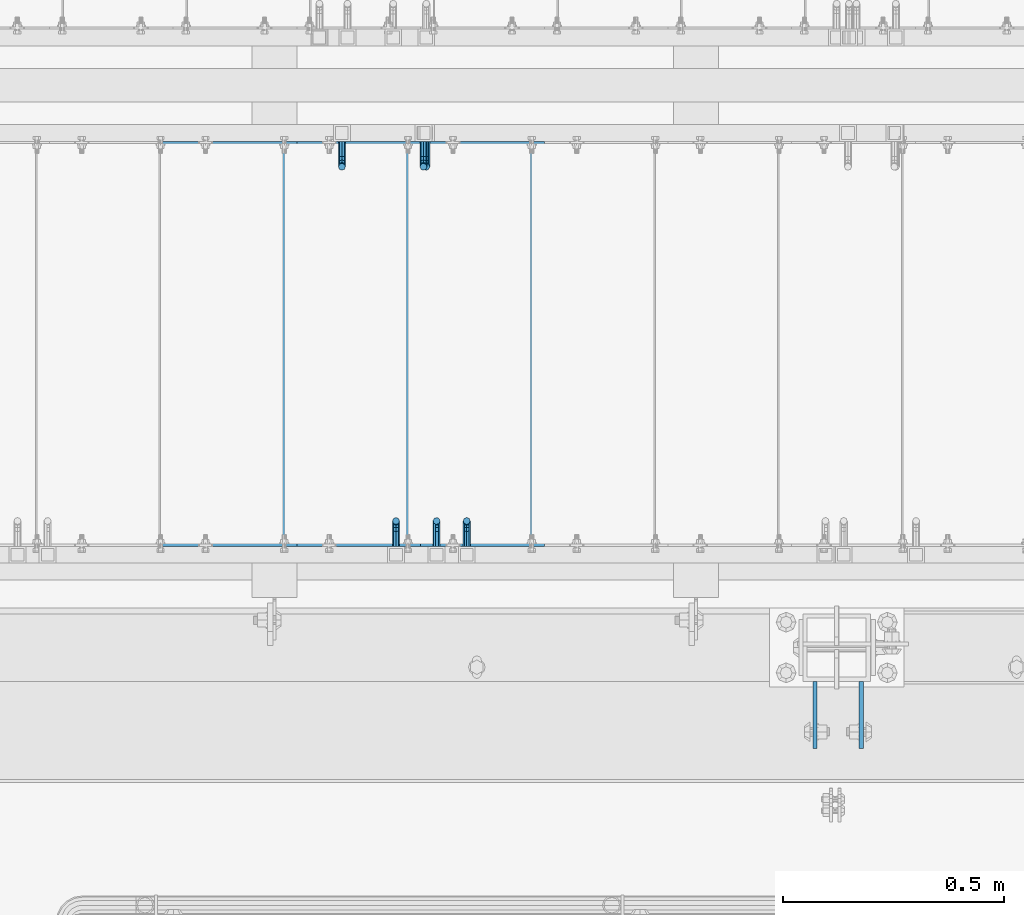
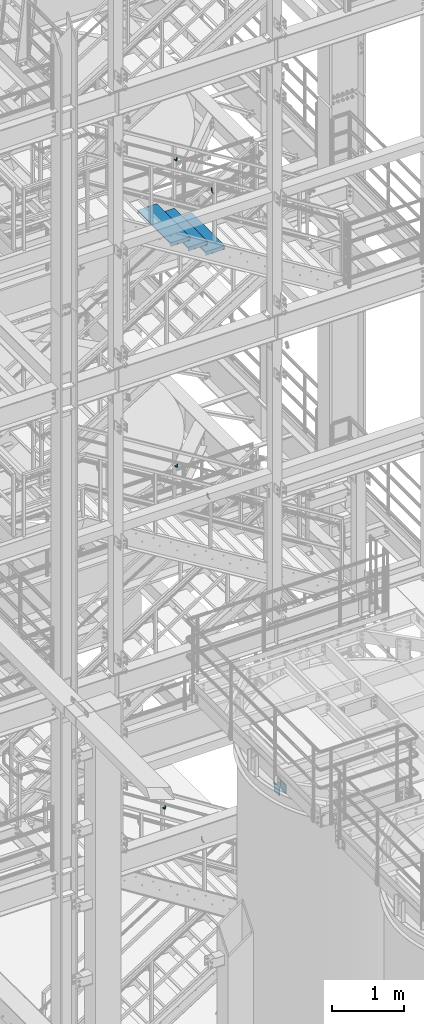
# One storey, part 1147 of 1876: 11 beams, 8 elements without a shape of their own.
"""IFC2X3 building model written with IfcOpenShell, lengths in millimetres."""

from ifc_helpers import new_model, si_unit, frame, origin_with_axes, place, context, subcontext, project, spatial, faceted_brep, material, type_object, element, aggregate, save


model = new_model("IFC2X3")

# Units and contexts
model_context = context("Model", 3, precision=1e-05, world=origin_with_axes())
body_context = subcontext(model_context, "Body", "Model", "MODEL_VIEW")
ifc_project = project(units=[si_unit("LENGTHUNIT", "METRE", prefix="MILLI"), si_unit("AREAUNIT", "SQUARE_METRE"), si_unit("VOLUMEUNIT", "CUBIC_METRE"), si_unit("MASSUNIT", "GRAM", prefix="KILO"), si_unit("TIMEUNIT", "SECOND"), si_unit("PLANEANGLEUNIT", "RADIAN"), si_unit("SOLIDANGLEUNIT", "STERADIAN"), si_unit("THERMODYNAMICTEMPERATUREUNIT", "DEGREE_CELSIUS"), si_unit("LUMINOUSINTENSITYUNIT", "LUMEN")], contexts=[model_context])

# Site, building, storey
site_placement = place(None, origin_with_axes())
site = spatial("IfcSite", under=ifc_project, at=site_placement, CompositionType="ELEMENT")
building_placement = place(site_placement, origin_with_axes())
building = spatial("IfcBuilding", under=site, at=building_placement, Name="Undefined", CompositionType="ELEMENT")
storey_placement = place(building_placement, origin_with_axes())
storey = spatial("IfcBuildingStorey", under=building, at=storey_placement, Name="Undefined", CompositionType="ELEMENT", Elevation=0.0)

# Assembly, beams
assembly_1_placement = place(storey_placement, origin_with_axes())
assembly_1 = element("IfcElementAssembly", 1, at=assembly_1_placement, inside=storey, Name="FRAME", AssemblyPlace="NOTDEFINED", PredefinedType="RIGID_FRAME")
ifc_material = material(Name="STEEL/A36")
beam_type_1 = type_object("IfcBeamType", PredefinedType="NOTDEFINED")
beam_1_placement = place(assembly_1_placement, frame((5030.7762944527, -7188.2, 5384.8), z_axis=(0.0, 0.0, -1.0), x_axis=(0.0, -1.0, 0.0)))
beam_1 = element("IfcBeam", 2, at=beam_1_placement, type_object=beam_type_1, material=ifc_material, Name="PLATE", context=body_context, shape_type="Brep", body=[
    faceted_brep([(0.0, 4.76249999999982, -76.1999999999998), (3.63797880709171e-12, 4.76249999999982, 76.1999969482422), (152.399993896484, 4.76250000000073, 76.1999969482422), (152.4, 4.76249999999982, -76.1999999999998), (3.63797880709171e-12, -4.76249999999982, 76.1999969482422), (152.399993896484, -4.76250000000073, 76.1999969482422), (0.0, -4.76249999999982, -76.1999999999998), (152.4, -4.76249999999982, -76.1999999999998)], [[[0, 1, 2, 3]], [[4, 5, 2, 1]], [[4, 6, 7, 5]], [[6, 0, 3, 7]], [[5, 7, 3, 2]], [[6, 4, 1, 0]]]),
])
beam_2_placement = place(assembly_1_placement, frame((5135.55129445271, -7188.2, 5384.8), z_axis=(0.0, 0.0, -1.0), x_axis=(0.0, -1.0, 0.0)))
beam_2 = element("IfcBeam", 3, at=beam_2_placement, type_object=beam_type_1, material=ifc_material, Name="PLATE", context=body_context, shape_type="Brep", body=[
    faceted_brep([(0.0, 4.76249999999982, -76.1999999999998), (3.63797880709171e-12, 4.76249999999982, 76.1999969482422), (152.399993896484, 4.76250000000073, 76.1999969482422), (152.4, 4.76249999999982, -76.1999999999998), (3.63797880709171e-12, -4.76249999999982, 76.1999969482422), (152.399993896484, -4.76250000000073, 76.1999969482422), (0.0, -4.76249999999982, -76.1999999999998), (152.4, -4.76249999999982, -76.1999999999998)], [[[0, 1, 2, 3]], [[4, 5, 2, 1]], [[4, 6, 7, 5]], [[6, 0, 3, 7]], [[5, 7, 3, 2]], [[6, 4, 1, 0]]]),
])
aggregate(assembly_1, [beam_1, beam_2])

# Assembly, beam
assembly_2_placement = place(storey_placement, origin_with_axes())
assembly_2 = element("IfcElementAssembly", 4, at=assembly_2_placement, inside=storey, Name="RAIL", AssemblyPlace="NOTDEFINED", PredefinedType="RIGID_FRAME")
beam_type_2 = type_object("IfcBeamType", PredefinedType="NOTDEFINED")
beam_3_placement = place(assembly_2_placement, frame((4176.18333383615, -6883.39999885446, 10341.2764937315), z_axis=(-0.851746923791363, 0.0, 0.523953411871657), x_axis=(0.0, 1.0, 0.0)))
beam_3 = element("IfcBeam", 5, at=beam_3_placement, type_object=beam_type_2, material=ifc_material, Name="BRACKET", context=body_context, shape_type="Brep", body=[
    faceted_brep([(0.0, -5.61266007566822, 5.61266007566883), (0.0, 0.0, 7.9375), (0.0, 5.61266007566822, 5.61266007566883), (0.0, 7.9375, 0.0), (0.0, 5.61266007566822, -5.61266007566883), (0.0, 0.0, -7.9375), (0.0, -5.61266007566822, -5.61266007566883), (0.0, -7.9375, 0.0), (23.8125, 7.9375, 0.0), (23.8125, 5.61266007566883, -5.61266007566792), (23.8125, 0.0, -7.9375), (23.8125, -5.61266007566883, -5.61266007566792), (23.8125, -7.9375, 0.0), (23.8125, -5.61266007566883, 5.61266007566792), (23.8125, 0.0, 7.9375), (23.8125, 5.61266007566883, 5.61266007566792), (37.2742680237907, 3.33192699189385, 7.01565649095653), (39.15743316105, 5.33771543479088, 1.59926141794483), (39.5250377726497, 2.95059483544173, -3.97508660603592), (38.1617440627024, -2.43109193407145, -6.44201010992776), (35.8661509970007, -7.65482575261558, -4.3564187624853), (33.9829858597423, -9.66061419551443, 1.05997631052549), (33.6153812481443, -7.27349359616528, 6.63432433450714), (34.9786749580899, -1.89180682665028, 9.10124783839899), (44.4449010004428, -7.27921686651098, 12.4153212945938), (48.6866038971966, -3.16305132232992, 11.0110522507902), (41.9258626896017, -12.0031473096369, 9.54377798901703), (42.605107443027, -14.5676282658369, 4.07853345752562), (46.0847428963316, -13.4704215714119, -0.778946175020906), (50.3264457930854, -9.35425602723262, -2.18321521882456), (52.8454841039247, -4.63032558410305, 0.688328086752222), (52.1662393505012, -2.0658446279067, 6.15357261824545), (56.3120829365644, -12.8834732957839, 16.9905845690854), (60.8584457511233, -13.1460552819772, 12.9695810055836), (50.7700310236578, -15.3420457780048, 17.3751827270333), (47.4787488596085, -19.0815743126295, 13.8980830945646), (48.3662248985192, -21.9114938009589, 8.59612347865811), (52.9125877130791, -22.1740757871521, 4.57511991515719), (58.4546396259857, -19.715503304933, 4.19052175720924), (61.7459217900359, -15.9759747703083, 7.66762138967886), (63.9107427334729, -26.2160548977063, 21.0096110902649), (64.8713398759373, -29.3590804831365, 15.9002591648249), (58.9897950832947, -24.3494927988595, 24.0439238549806), (52.991121319149, -24.8528009490874, 23.2257381938842), (49.4286631758196, -27.4311482600406, 19.0343361707063), (50.389260318284, -30.5741738454726, 13.9249842452672), (55.3102079684622, -32.4407359443194, 10.8906714805506), (61.3088817326088, -31.9374277940915, 11.7088571416479), (64.8713398759373, -56.6704316393188, 32.700878247072), (61.3088817326088, -56.6704314004855, 26.9234018184987), (55.3102079684622, -56.670431353863, 25.7956053568267), (50.389260318284, -56.6704315267634, 29.9781367337081), (49.4286631758196, -56.6704318179036, 37.0209257936175), (52.991121319149, -56.6704320567369, 42.7984022221907), (58.9897950832947, -56.6704321033558, 43.9261986838618), (63.9107427334739, -56.6704319304572, 39.7436673069795)], [[[0, 1, 2, 3, 4, 5, 6, 7]], [[4, 3, 8, 9]], [[5, 4, 9, 10]], [[6, 5, 10, 11]], [[7, 6, 11, 12]], [[0, 7, 12, 13]], [[1, 0, 13, 14]], [[2, 1, 14, 15]], [[3, 2, 15, 8]], [[8, 15, 16, 17]], [[9, 8, 17, 18]], [[10, 9, 18, 19]], [[11, 10, 19, 20]], [[12, 11, 20, 21]], [[13, 12, 21, 22]], [[14, 13, 22, 23]], [[15, 14, 23, 16]], [[23, 24, 25, 16]], [[22, 26, 24, 23]], [[21, 27, 26, 22]], [[20, 28, 27, 21]], [[19, 29, 28, 20]], [[18, 30, 29, 19]], [[17, 31, 30, 18]], [[16, 25, 31, 17]], [[25, 32, 33, 31]], [[24, 34, 32, 25]], [[26, 35, 34, 24]], [[27, 36, 35, 26]], [[28, 37, 36, 27]], [[29, 38, 37, 28]], [[30, 39, 38, 29]], [[31, 33, 39, 30]], [[33, 40, 41, 39]], [[32, 42, 40, 33]], [[34, 43, 42, 32]], [[35, 44, 43, 34]], [[36, 45, 44, 35]], [[37, 46, 45, 36]], [[38, 47, 46, 37]], [[39, 41, 47, 38]], [[47, 41, 48, 49]], [[46, 47, 49, 50]], [[45, 46, 50, 51]], [[44, 45, 51, 52]], [[43, 44, 52, 53]], [[42, 43, 53, 54]], [[40, 42, 54, 55]], [[41, 40, 55, 48]], [[54, 53, 52, 51, 50, 49, 48, 55]]]),
])
aggregate(assembly_2, [beam_3])

assembly_3_placement = place(storey_placement, origin_with_axes())
assembly_3 = element("IfcElementAssembly", 6, at=assembly_3_placement, inside=storey, Name="RAIL", AssemblyPlace="NOTDEFINED", PredefinedType="RIGID_FRAME")
beam_4_placement = place(assembly_3_placement, frame((4084.63750452115, -6883.39999893226, 4583.05350179097), z_axis=(-1.0, 0.0, 0.0), x_axis=(0.0, 1.0, 0.0)))
beam_4 = element("IfcBeam", 7, at=beam_4_placement, type_object=beam_type_2, material=ifc_material, Name="BRACKET", context=body_context, shape_type="Brep", body=[
    faceted_brep([(0.0, -5.61266007566822, 5.61266007566883), (0.0, 0.0, 7.9375), (0.0, 5.61266007566822, 5.61266007566883), (0.0, 7.9375, 0.0), (0.0, 5.61266007566822, -5.61266007566883), (0.0, 0.0, -7.9375), (0.0, -5.61266007566822, -5.61266007566883), (0.0, -7.9375, 0.0), (23.8125, 5.61266007566883, 5.61266007566792), (23.8125, 7.9375, 0.0), (23.8125, 5.61266007566883, -5.61266007566792), (23.8125, 0.0, -7.9375), (23.8125, -5.61266007566883, -5.61266007566792), (23.8125, -7.9375, 0.0), (23.8125, -5.61266007566883, 5.61266007566792), (23.8125, 0.0, 7.9375), (36.5702095103989, -2.53766620105534, 7.9375), (38.7180815328547, 2.64775556579752, 5.61266007566792), (39.6077592547972, 4.79562758825296, 0.0), (38.7180815328547, 2.64775556579752, -5.61266007566792), (36.5702095103989, -2.53766620105534, -7.9375), (34.4223374879439, -7.72308796790867, -5.61266007566792), (33.5326597660014, -9.87095999036364, 0.0), (34.4223374879439, -7.72308796790867, 5.61266007566792), (43.4169233967659, -13.733078129113, 5.61266007566792), (47.385673396765, -9.76432812911298, 7.9375), (41.7730133210971, -15.3769882047809, 0.0), (43.4169233967659, -13.733078129113, -5.61266007566792), (47.385673396765, -9.76432812911298, -7.9375), (51.354423396765, -5.79557812911253, -5.61266007566792), (52.9983334724338, -4.15166805344461, 0.0), (51.354423396765, -5.79557812911253, 5.61266007566792), (54.6123353248231, -20.5797920154787, 7.9375), (59.7977570916764, -18.4319199930233, 5.61266007566792), (49.4269135579698, -22.7276640379341, 5.61266007566792), (47.2790415355148, -23.6173417598766, 0.0), (49.4269135579698, -22.7276640379341, -5.61266007566792), (54.6123353248231, -20.5797920154787, -7.9375), (59.7977570916764, -18.4319199930233, -5.61266007566792), (61.9456291141314, -17.5422422710808, 0.0), (62.7626616015468, -33.3375015258789, 5.61266007566792), (65.0875015258789, -33.3375015258789, 0.0), (57.1500015258789, -33.3375015258789, 7.9375), (51.5373414502101, -33.3375015258789, 5.61266007566792), (49.2125015258789, -33.3375015258789, 0.0), (51.5373414502101, -33.3375015258789, -5.61266007566792), (57.1500015258789, -33.3375015258789, -7.9375), (62.7626616015468, -33.3375015258789, -5.61266007566792), (65.0875015258789, -66.3399314131093, 0.0), (62.7626616015468, -62.779234846751, -5.61266007566792), (57.1500015258789, -61.3043460374702, -7.9375), (51.537341450211, -62.779234846751, -5.61266007566792), (49.2125015258789, -66.3399314131093, 0.0), (51.537341450211, -69.9006279794671, 5.61266007566792), (57.1500015258789, -71.375516788748, 7.9375), (62.7626616015468, -69.9006279794671, 5.61266007566792)], [[[0, 1, 2, 3, 4, 5, 6, 7]], [[3, 2, 8, 9]], [[4, 3, 9, 10]], [[5, 4, 10, 11]], [[6, 5, 11, 12]], [[7, 6, 12, 13]], [[0, 7, 13, 14]], [[1, 0, 14, 15]], [[2, 1, 15, 8]], [[8, 15, 16, 17]], [[9, 8, 17, 18]], [[10, 9, 18, 19]], [[11, 10, 19, 20]], [[12, 11, 20, 21]], [[13, 12, 21, 22]], [[14, 13, 22, 23]], [[15, 14, 23, 16]], [[23, 24, 25, 16]], [[22, 26, 24, 23]], [[21, 27, 26, 22]], [[20, 28, 27, 21]], [[19, 29, 28, 20]], [[18, 30, 29, 19]], [[17, 31, 30, 18]], [[16, 25, 31, 17]], [[25, 32, 33, 31]], [[24, 34, 32, 25]], [[26, 35, 34, 24]], [[27, 36, 35, 26]], [[28, 37, 36, 27]], [[29, 38, 37, 28]], [[30, 39, 38, 29]], [[31, 33, 39, 30]], [[33, 40, 41, 39]], [[32, 42, 40, 33]], [[34, 43, 42, 32]], [[35, 44, 43, 34]], [[36, 45, 44, 35]], [[37, 46, 45, 36]], [[38, 47, 46, 37]], [[39, 41, 47, 38]], [[47, 41, 48, 49]], [[46, 47, 49, 50]], [[45, 46, 50, 51]], [[44, 45, 51, 52]], [[43, 44, 52, 53]], [[42, 43, 53, 54]], [[40, 42, 54, 55]], [[41, 40, 55, 48]], [[54, 53, 52, 51, 50, 49, 48, 55]]]),
])
aggregate(assembly_3, [beam_4])

assembly_4_placement = place(storey_placement, origin_with_axes())
assembly_4 = element("IfcElementAssembly", 8, at=assembly_4_placement, inside=storey, Name="RAIL", AssemblyPlace="NOTDEFINED", PredefinedType="RIGID_FRAME")
beam_5_placement = place(assembly_4_placement, frame((4152.9000005767, -5969.00000114554, 10355.5992686804), z_axis=(-1.0, 0.0, 0.0), x_axis=(0.0, -1.0, 0.0)))
beam_5 = element("IfcBeam", 9, at=beam_5_placement, type_object=beam_type_2, material=ifc_material, Name="BRACKET", context=body_context, shape_type="Brep", body=[
    faceted_brep([(0.0, -5.61266007566822, 5.61266007566883), (0.0, 0.0, 7.9375), (0.0, 5.61266007566822, 5.61266007566883), (0.0, 7.9375, 0.0), (0.0, 5.61266007566822, -5.61266007566883), (0.0, 0.0, -7.9375), (0.0, -5.61266007566822, -5.61266007566883), (0.0, -7.9375, 0.0), (23.8125, -5.61266007566883, -5.61266007566792), (23.8125, -7.9375, 0.0), (23.8125, -5.61266007566883, 5.61266007566792), (23.8125, 0.0, 7.9375), (23.8125, 5.61266007566883, 5.61266007566792), (23.8125, 7.9375, 0.0), (23.8125, 5.61266007566883, -5.61266007566792), (23.8125, 0.0, -7.9375), (36.5702095103998, 2.53766620105671, -7.9375), (38.7180815328556, -2.64775556579843, -5.61266007566792), (39.6077592547981, -4.79562758825341, 0.0), (38.7180815328556, -2.64775556579843, 5.61266007566792), (36.5702095103998, 2.53766620105671, 7.9375), (34.4223374879448, 7.72308796790821, 5.61266007566792), (33.5326597660023, 9.87095999036319, 0.0), (34.4223374879448, 7.72308796790821, -5.61266007566792), (43.4169233967659, 13.733078129113, -5.61266007566792), (47.3856733967659, 9.76432812911298, -7.9375), (41.773013321098, 15.3769882047818, 0.0), (43.4169233967659, 13.733078129113, 5.61266007566792), (47.3856733967659, 9.76432812911298, 7.9375), (51.3544233967659, 5.79557812911298, 5.61266007566792), (52.9983334724348, 4.15166805344415, 0.0), (51.3544233967659, 5.79557812911298, -5.61266007566792), (54.6123353248231, 20.5797920154801, -7.9375), (59.7977570916764, 18.4319199930251, -5.61266007566792), (49.4269135579698, 22.727664037935, -5.61266007566792), (47.2790415355148, 23.6173417598766, 0.0), (49.4269135579698, 22.727664037935, 5.61266007566792), (54.6123353248231, 20.5797920154801, 7.9375), (59.7977570916764, 18.4319199930251, 5.61266007566792), (61.9456291141314, 17.5422422710835, 0.0), (62.7626616015468, 33.3375015258789, -5.61266007566792), (65.0875015258789, 33.3375015258789, 0.0), (57.1500015258789, 33.3375015258789, -7.9375), (51.5373414502101, 33.3375015258789, -5.61266007566792), (49.2125015258789, 33.3375015258789, 0.0), (51.5373414502101, 33.3375015258789, 5.61266007566792), (57.1500015258789, 33.3375015258789, 7.9375), (62.7626616015468, 33.3375015258789, 5.61266007566792), (65.0875015258789, 66.616627667634, 0.0), (62.7626616015468, 70.0692642717895, 5.61266007566837), (57.1500015258789, 71.4993931791778, 7.9375), (51.537341450211, 70.0692642717895, 5.61266007566837), (49.2125015258789, 66.616627667634, 0.0), (51.537341450211, 63.1639910634785, -5.61266007566837), (57.1500015258789, 61.7338621560921, -7.9375), (62.7626616015468, 63.1639910634785, -5.61266007566837)], [[[0, 1, 2, 3, 4, 5, 6, 7]], [[7, 6, 8, 9]], [[0, 7, 9, 10]], [[1, 0, 10, 11]], [[2, 1, 11, 12]], [[3, 2, 12, 13]], [[4, 3, 13, 14]], [[5, 4, 14, 15]], [[6, 5, 15, 8]], [[8, 15, 16, 17]], [[9, 8, 17, 18]], [[10, 9, 18, 19]], [[11, 10, 19, 20]], [[12, 11, 20, 21]], [[13, 12, 21, 22]], [[14, 13, 22, 23]], [[15, 14, 23, 16]], [[23, 24, 25, 16]], [[22, 26, 24, 23]], [[21, 27, 26, 22]], [[20, 28, 27, 21]], [[19, 29, 28, 20]], [[18, 30, 29, 19]], [[17, 31, 30, 18]], [[16, 25, 31, 17]], [[25, 32, 33, 31]], [[24, 34, 32, 25]], [[26, 35, 34, 24]], [[27, 36, 35, 26]], [[28, 37, 36, 27]], [[29, 38, 37, 28]], [[30, 39, 38, 29]], [[31, 33, 39, 30]], [[33, 40, 41, 39]], [[32, 42, 40, 33]], [[34, 43, 42, 32]], [[35, 44, 43, 34]], [[36, 45, 44, 35]], [[37, 46, 45, 36]], [[38, 47, 46, 37]], [[39, 41, 47, 38]], [[47, 41, 48, 49]], [[46, 47, 49, 50]], [[45, 46, 50, 51]], [[44, 45, 51, 52]], [[43, 44, 52, 53]], [[42, 43, 53, 54]], [[40, 42, 54, 55]], [[41, 40, 55, 48]], [[54, 53, 52, 51, 50, 49, 48, 55]]]),
])
aggregate(assembly_4, [beam_5])

assembly_5_placement = place(storey_placement, origin_with_axes())
assembly_5 = element("IfcElementAssembly", 10, at=assembly_5_placement, inside=storey, Name="RAIL", AssemblyPlace="NOTDEFINED", PredefinedType="RIGID_FRAME")
beam_6_placement = place(assembly_5_placement, frame((4146.55000058227, -5969.00000114554, 15525.4614199387), z_axis=(-1.0, 0.0, 0.0), x_axis=(0.0, -1.0, 0.0)))
beam_6 = element("IfcBeam", 11, at=beam_6_placement, type_object=beam_type_2, material=ifc_material, Name="BRACKET", context=body_context, shape_type="Brep", body=[
    faceted_brep([(0.0, -5.61266007566822, 5.61266007566883), (0.0, 0.0, 7.9375), (0.0, 5.61266007566822, 5.61266007566883), (0.0, 7.9375, 0.0), (0.0, 5.61266007566822, -5.61266007566883), (0.0, 0.0, -7.9375), (0.0, -5.61266007566822, -5.61266007566883), (0.0, -7.9375, 0.0), (23.8125, -5.61266007566883, -5.61266007566792), (23.8125, -7.9375, 0.0), (23.8125, -5.61266007566883, 5.61266007566792), (23.8125, 0.0, 7.9375), (23.8125, 5.61266007566883, 5.61266007566792), (23.8125, 7.9375, 0.0), (23.8125, 5.61266007566883, -5.61266007566792), (23.8125, 0.0, -7.9375), (36.5702095103998, 2.53766620105671, -7.9375), (38.7180815328556, -2.64775556579843, -5.61266007566792), (39.6077592547981, -4.79562758825341, 0.0), (38.7180815328556, -2.64775556579843, 5.61266007566792), (36.5702095103998, 2.53766620105671, 7.9375), (34.4223374879448, 7.72308796790821, 5.61266007566792), (33.5326597660023, 9.87095999036319, 0.0), (34.4223374879448, 7.72308796790821, -5.61266007566792), (43.4169233967659, 13.733078129113, -5.61266007566792), (47.3856733967659, 9.76432812911298, -7.9375), (41.773013321098, 15.3769882047818, 0.0), (43.4169233967659, 13.733078129113, 5.61266007566792), (47.3856733967659, 9.76432812911298, 7.9375), (51.3544233967659, 5.79557812911298, 5.61266007566792), (52.9983334724348, 4.15166805344415, 0.0), (51.3544233967659, 5.79557812911298, -5.61266007566792), (54.6123353248231, 20.5797920154801, -7.9375), (59.7977570916764, 18.4319199930251, -5.61266007566792), (49.4269135579698, 22.727664037935, -5.61266007566792), (47.2790415355148, 23.6173417598766, 0.0), (49.4269135579698, 22.727664037935, 5.61266007566792), (54.6123353248231, 20.5797920154801, 7.9375), (59.7977570916764, 18.4319199930251, 5.61266007566792), (61.9456291141314, 17.5422422710835, 0.0), (62.7626616015468, 33.3375015258789, -5.61266007566792), (65.0875015258789, 33.3375015258789, 0.0), (57.1500015258789, 33.3375015258789, -7.9375), (51.5373414502101, 33.3375015258789, -5.61266007566792), (49.2125015258789, 33.3375015258789, 0.0), (51.5373414502101, 33.3375015258789, 5.61266007566792), (57.1500015258789, 33.3375015258789, 7.9375), (62.7626616015468, 33.3375015258789, 5.61266007566792), (65.0875015258789, 66.5774551740215, 0.0), (62.7626616015468, 70.0546586046949, 5.61266007566792), (57.1500015258789, 71.4949634248096, 7.9375), (51.537341450211, 70.0546586046949, 5.61266007566792), (49.2125015258789, 66.5774551740215, 0.0), (51.537341450211, 63.1002517433481, -5.61266007566792), (57.1500015258789, 61.6599469232333, -7.9375), (62.7626616015468, 63.1002517433481, -5.61266007566792)], [[[0, 1, 2, 3, 4, 5, 6, 7]], [[7, 6, 8, 9]], [[0, 7, 9, 10]], [[1, 0, 10, 11]], [[2, 1, 11, 12]], [[3, 2, 12, 13]], [[4, 3, 13, 14]], [[5, 4, 14, 15]], [[6, 5, 15, 8]], [[8, 15, 16, 17]], [[9, 8, 17, 18]], [[10, 9, 18, 19]], [[11, 10, 19, 20]], [[12, 11, 20, 21]], [[13, 12, 21, 22]], [[14, 13, 22, 23]], [[15, 14, 23, 16]], [[23, 24, 25, 16]], [[22, 26, 24, 23]], [[21, 27, 26, 22]], [[20, 28, 27, 21]], [[19, 29, 28, 20]], [[18, 30, 29, 19]], [[17, 31, 30, 18]], [[16, 25, 31, 17]], [[25, 32, 33, 31]], [[24, 34, 32, 25]], [[26, 35, 34, 24]], [[27, 36, 35, 26]], [[28, 37, 36, 27]], [[29, 38, 37, 28]], [[30, 39, 38, 29]], [[31, 33, 39, 30]], [[33, 40, 41, 39]], [[32, 42, 40, 33]], [[34, 43, 42, 32]], [[35, 44, 43, 34]], [[36, 45, 44, 35]], [[37, 46, 45, 36]], [[38, 47, 46, 37]], [[39, 41, 47, 38]], [[47, 41, 48, 49]], [[46, 47, 49, 50]], [[45, 46, 50, 51]], [[44, 45, 51, 52]], [[43, 44, 52, 53]], [[42, 43, 53, 54]], [[40, 42, 54, 55]], [[41, 40, 55, 48]], [[54, 53, 52, 51, 50, 49, 48, 55]]]),
])
aggregate(assembly_5, [beam_6])

assembly_6_placement = place(storey_placement, origin_with_axes())
assembly_6 = element("IfcElementAssembly", 12, at=assembly_6_placement, inside=storey, Name="RAIL", AssemblyPlace="NOTDEFINED", PredefinedType="RIGID_FRAME")
beam_7_placement = place(assembly_6_placement, frame((4244.34000046609, -6883.39999885446, 15464.8776876491), z_axis=(-1.0, 0.0, 0.0), x_axis=(0.0, 1.0, 0.0)))
beam_7 = element("IfcBeam", 13, at=beam_7_placement, type_object=beam_type_2, material=ifc_material, Name="BRACKET", context=body_context, shape_type="Brep", body=[
    faceted_brep([(0.0, -5.61266007566822, 5.61266007566883), (0.0, 0.0, 7.9375), (0.0, 5.61266007566822, 5.61266007566883), (0.0, 7.9375, 0.0), (0.0, 5.61266007566822, -5.61266007566883), (0.0, 0.0, -7.9375), (0.0, -5.61266007566822, -5.61266007566883), (0.0, -7.9375, 0.0), (23.8125, 5.61266007566883, 5.61266007566792), (23.8125, 7.9375, 0.0), (23.8125, 5.61266007566883, -5.61266007566792), (23.8125, 0.0, -7.9375), (23.8125, -5.61266007566883, -5.61266007566792), (23.8125, -7.9375, 0.0), (23.8125, -5.61266007566883, 5.61266007566792), (23.8125, 0.0, 7.9375), (36.5702095103989, -2.53766620105534, 7.9375), (38.7180815328547, 2.64775556579752, 5.61266007566792), (39.6077592547972, 4.79562758825296, 0.0), (38.7180815328547, 2.64775556579752, -5.61266007566792), (36.5702095103989, -2.53766620105534, -7.9375), (34.4223374879439, -7.72308796790867, -5.61266007566792), (33.5326597660014, -9.87095999036364, 0.0), (34.4223374879439, -7.72308796790867, 5.61266007566792), (43.4169233967659, -13.733078129113, 5.61266007566792), (47.385673396765, -9.76432812911298, 7.9375), (41.7730133210971, -15.3769882047809, 0.0), (43.4169233967659, -13.733078129113, -5.61266007566792), (47.385673396765, -9.76432812911298, -7.9375), (51.354423396765, -5.79557812911253, -5.61266007566792), (52.9983334724338, -4.15166805344461, 0.0), (51.354423396765, -5.79557812911253, 5.61266007566792), (54.6123353248231, -20.5797920154787, 7.9375), (59.7977570916764, -18.4319199930233, 5.61266007566792), (49.4269135579698, -22.7276640379341, 5.61266007566792), (47.2790415355148, -23.6173417598766, 0.0), (49.4269135579698, -22.7276640379341, -5.61266007566792), (54.6123353248231, -20.5797920154787, -7.9375), (59.7977570916764, -18.4319199930233, -5.61266007566792), (61.9456291141314, -17.5422422710808, 0.0), (62.7626616015468, -33.3375015258789, 5.61266007566792), (65.0875015258789, -33.3375015258789, 0.0), (57.1500015258789, -33.3375015258789, 7.9375), (51.5373414502101, -33.3375015258789, 5.61266007566792), (49.2125015258789, -33.3375015258789, 0.0), (51.5373414502101, -33.3375015258789, -5.61266007566792), (57.1500015258789, -33.3375015258789, -7.9375), (62.7626616015468, -33.3375015258789, -5.61266007566792), (65.0875015258789, -66.4903966648035, 0.0), (62.7626616015468, -63.0131930011103, -5.61266007566792), (57.1500015258789, -61.5728880844745, -7.9375), (51.537341450211, -63.0131930011103, -5.61266007566792), (49.2125015258789, -66.4903966648035, 0.0), (51.537341450211, -69.9676003284985, 5.61266007566792), (57.1500015258789, -71.4079052451343, 7.9375), (62.7626616015468, -69.9676003284985, 5.61266007566792)], [[[0, 1, 2, 3, 4, 5, 6, 7]], [[3, 2, 8, 9]], [[4, 3, 9, 10]], [[5, 4, 10, 11]], [[6, 5, 11, 12]], [[7, 6, 12, 13]], [[0, 7, 13, 14]], [[1, 0, 14, 15]], [[2, 1, 15, 8]], [[8, 15, 16, 17]], [[9, 8, 17, 18]], [[10, 9, 18, 19]], [[11, 10, 19, 20]], [[12, 11, 20, 21]], [[13, 12, 21, 22]], [[14, 13, 22, 23]], [[15, 14, 23, 16]], [[23, 24, 25, 16]], [[22, 26, 24, 23]], [[21, 27, 26, 22]], [[20, 28, 27, 21]], [[19, 29, 28, 20]], [[18, 30, 29, 19]], [[17, 31, 30, 18]], [[16, 25, 31, 17]], [[25, 32, 33, 31]], [[24, 34, 32, 25]], [[26, 35, 34, 24]], [[27, 36, 35, 26]], [[28, 37, 36, 27]], [[29, 38, 37, 28]], [[30, 39, 38, 29]], [[31, 33, 39, 30]], [[33, 40, 41, 39]], [[32, 42, 40, 33]], [[34, 43, 42, 32]], [[35, 44, 43, 34]], [[36, 45, 44, 35]], [[37, 46, 45, 36]], [[38, 47, 46, 37]], [[39, 41, 47, 38]], [[47, 41, 48, 49]], [[46, 47, 49, 50]], [[45, 46, 50, 51]], [[44, 45, 51, 52]], [[43, 44, 52, 53]], [[42, 43, 53, 54]], [[40, 42, 54, 55]], [[41, 40, 55, 48]], [[54, 53, 52, 51, 50, 49, 48, 55]]]),
])
aggregate(assembly_6, [beam_7])

assembly_7_placement = place(storey_placement, origin_with_axes())
assembly_7 = element("IfcElementAssembly", 14, at=assembly_7_placement, inside=storey, Name="RAIL", AssemblyPlace="NOTDEFINED", PredefinedType="RIGID_FRAME")
beam_8_placement = place(assembly_7_placement, frame((3962.40000306368, -5969.00000106773, 4659.58537699934), z_axis=(-1.0, 0.0, 0.0), x_axis=(0.0, -1.0, 0.0)))
beam_8 = element("IfcBeam", 15, at=beam_8_placement, type_object=beam_type_2, material=ifc_material, Name="BRACKET", context=body_context, shape_type="Brep", body=[
    faceted_brep([(0.0, -5.61266007566822, 5.61266007566883), (0.0, 0.0, 7.9375), (0.0, 5.61266007566822, 5.61266007566883), (0.0, 7.9375, 0.0), (0.0, 5.61266007566822, -5.61266007566883), (0.0, 0.0, -7.9375), (0.0, -5.61266007566822, -5.61266007566883), (0.0, -7.9375, 0.0), (23.8125, -5.61266007566883, -5.61266007566792), (23.8125, -7.9375, 0.0), (23.8125, -5.61266007566883, 5.61266007566792), (23.8125, 0.0, 7.9375), (23.8125, 5.61266007566883, 5.61266007566792), (23.8125, 7.9375, 0.0), (23.8125, 5.61266007566883, -5.61266007566792), (23.8125, 0.0, -7.9375), (36.5702095103998, 2.53766620105671, -7.9375), (38.7180815328556, -2.64775556579843, -5.61266007566792), (39.6077592547981, -4.79562758825341, 0.0), (38.7180815328556, -2.64775556579843, 5.61266007566792), (36.5702095103998, 2.53766620105671, 7.9375), (34.4223374879448, 7.72308796790821, 5.61266007566792), (33.5326597660023, 9.87095999036319, 0.0), (34.4223374879448, 7.72308796790821, -5.61266007566792), (43.4169233967659, 13.733078129113, -5.61266007566792), (47.3856733967659, 9.76432812911298, -7.9375), (41.773013321098, 15.3769882047818, 0.0), (43.4169233967659, 13.733078129113, 5.61266007566792), (47.3856733967659, 9.76432812911298, 7.9375), (51.3544233967659, 5.79557812911298, 5.61266007566792), (52.9983334724348, 4.15166805344415, 0.0), (51.3544233967659, 5.79557812911298, -5.61266007566792), (54.6123353248231, 20.5797920154801, -7.9375), (59.7977570916764, 18.4319199930251, -5.61266007566792), (49.4269135579698, 22.727664037935, -5.61266007566792), (47.2790415355148, 23.6173417598766, 0.0), (49.4269135579698, 22.727664037935, 5.61266007566792), (54.6123353248231, 20.5797920154801, 7.9375), (59.7977570916764, 18.4319199930251, 5.61266007566792), (61.9456291141314, 17.5422422710835, 0.0), (62.7626616015468, 33.3375015258789, -5.61266007566792), (65.0875015258789, 33.3375015258789, 0.0), (57.1500015258789, 33.3375015258789, -7.9375), (51.5373414502101, 33.3375015258789, -5.61266007566792), (49.2125015258789, 33.3375015258789, 0.0), (51.5373414502101, 33.3375015258789, 5.61266007566792), (57.1500015258789, 33.3375015258789, 7.9375), (62.7626616015468, 33.3375015258789, 5.61266007566792), (65.0875015258789, 67.3558732176816, 0.0), (62.7626616015468, 70.9165696288755, 5.61266007566837), (57.1500015258789, 72.3914583738861, 7.9375), (51.537341450211, 70.9165696288755, 5.61266007566837), (49.2125015258789, 67.3558732176816, 0.0), (51.537341450211, 63.7951768064877, -5.61266007566837), (57.1500015258789, 62.3202880614781, -7.9375), (62.7626616015468, 63.7951768064877, -5.61266007566837)], [[[0, 1, 2, 3, 4, 5, 6, 7]], [[7, 6, 8, 9]], [[0, 7, 9, 10]], [[1, 0, 10, 11]], [[2, 1, 11, 12]], [[3, 2, 12, 13]], [[4, 3, 13, 14]], [[5, 4, 14, 15]], [[6, 5, 15, 8]], [[8, 15, 16, 17]], [[9, 8, 17, 18]], [[10, 9, 18, 19]], [[11, 10, 19, 20]], [[12, 11, 20, 21]], [[13, 12, 21, 22]], [[14, 13, 22, 23]], [[15, 14, 23, 16]], [[23, 24, 25, 16]], [[22, 26, 24, 23]], [[21, 27, 26, 22]], [[20, 28, 27, 21]], [[19, 29, 28, 20]], [[18, 30, 29, 19]], [[17, 31, 30, 18]], [[16, 25, 31, 17]], [[25, 32, 33, 31]], [[24, 34, 32, 25]], [[26, 35, 34, 24]], [[27, 36, 35, 26]], [[28, 37, 36, 27]], [[29, 38, 37, 28]], [[30, 39, 38, 29]], [[31, 33, 39, 30]], [[33, 40, 41, 39]], [[32, 42, 40, 33]], [[34, 43, 42, 32]], [[35, 44, 43, 34]], [[36, 45, 44, 35]], [[37, 46, 45, 36]], [[38, 47, 46, 37]], [[39, 41, 47, 38]], [[47, 41, 48, 49]], [[46, 47, 49, 50]], [[45, 46, 50, 51]], [[44, 45, 51, 52]], [[43, 44, 52, 53]], [[42, 43, 53, 54]], [[40, 42, 54, 55]], [[41, 40, 55, 48]], [[54, 53, 52, 51, 50, 49, 48, 55]]]),
])
aggregate(assembly_7, [beam_8])

# Assembly, beams
assembly_8_placement = place(storey_placement, origin_with_axes())
assembly_8 = element("IfcElementAssembly", 16, at=assembly_8_placement, inside=storey, Name="STRINGER", AssemblyPlace="NOTDEFINED", PredefinedType="RIGID_FRAME")
beam_type_3 = type_object("IfcBeamType", PredefinedType="NOTDEFINED")
beam_9_placement = place(assembly_8_placement, frame((3706.81250109009, -5973.76300114714, 14867.4666666671), z_axis=(1.0, 0.0, 0.0), x_axis=(0.0, -1.0, 0.0)))
beam_9 = element("IfcBeam", 17, at=beam_9_placement, type_object=beam_type_3, material=ifc_material, Name="TREAD", context=body_context, shape_type="Brep", body=[
    faceted_brep([(-7.45785655453801e-11, 53.9750000000167, -153.9875), (-7.45785655453801e-11, 53.9750000000167, 153.987506103515), (0.0, 9.52499999999964, 153.9875), (-7.45785655453801e-11, 9.52499999999964, -153.9875), (-4.76300000007541, 53.9750000000167, -153.9875), (-4.76300000007541, 53.9750000000167, 153.987506103515), (-4.76300000007541, -9.52499999998327, -153.9875), (-4.76300000007541, -9.52500000019427, 153.987536621094), (909.637000008669, -9.52500000248983, 153.987506103515), (909.637000008669, 53.9749999975102, 153.987506103515), (904.87400000867, 53.9749999975102, 153.987506103515), (904.87400000867, 9.52499999999964, 153.987506103515), (-7.45785655453801e-11, -9.52500000019427, 153.987536621094), (904.87400000867, -9.52500000248983, 153.987506103515), (904.87400000867, 9.52499999999964, -153.9875), (909.637000008669, -9.52500000248983, -153.9875), (909.637000008669, 53.9749999975102, -153.9875), (904.87400000867, 53.9749999975102, -153.9875)], [[[0, 1, 2, 3]], [[1, 0, 4, 5]], [[5, 4, 6, 7]], [[8, 9, 10, 11, 2, 1, 5, 7, 12, 13]], [[14, 3, 2, 11]], [[15, 8, 13, 12, 7, 6]], [[9, 16, 17, 10]], [[16, 9, 8, 15]], [[16, 15, 6, 4, 0, 3, 14, 17]], [[10, 17, 14, 11]]]),
])
beam_10_placement = place(assembly_8_placement, frame((3986.21250101169, -5973.76300114695, 14694.3703703708), z_axis=(1.0, 0.0, 0.0), x_axis=(0.0, -1.0, 0.0)))
beam_10 = element("IfcBeam", 18, at=beam_10_placement, type_object=beam_type_3, material=ifc_material, Name="TREAD", context=body_context, shape_type="Brep", body=[
    faceted_brep([(-7.45785655453801e-11, 53.9750000000167, -153.9875), (-7.45785655453801e-11, 53.9750000000167, 153.987506103515), (0.0, 9.52499999999964, 153.9875), (-7.45785655453801e-11, 9.52499999999964, -153.9875), (-4.76300000007541, 53.9750000000167, -153.9875), (-4.76300000007541, 53.9750000000167, 153.987506103515), (-4.76300000007541, -9.52499999998327, -153.9875), (-4.76300000007541, -9.52500000019427, 153.987536621094), (909.637000008669, 53.9749999975102, 153.987506103515), (904.87400000867, 53.9749999975102, 153.987506103515), (904.87400000867, 9.52499999999964, 153.987506103515), (909.637000008669, -9.52500000248983, 153.987506103515), (904.87400000867, 9.52499999999964, -153.9875), (909.637000008669, -9.52500000248983, -153.9875), (909.637000008669, 53.9749999975102, -153.9875), (904.87400000867, 53.9749999975102, -153.9875)], [[[0, 1, 2, 3]], [[1, 0, 4, 5]], [[5, 4, 6, 7]], [[8, 9, 10, 2, 1, 5, 7, 11]], [[12, 3, 2, 10]], [[13, 11, 7, 6]], [[8, 14, 15, 9]], [[14, 8, 11, 13]], [[14, 13, 6, 4, 0, 3, 12, 15]], [[9, 15, 12, 10]]]),
])
beam_11_placement = place(assembly_8_placement, frame((4265.61250093329, -5973.76300114682, 14521.2740740745), z_axis=(1.0, 0.0, 0.0), x_axis=(0.0, -1.0, 0.0)))
beam_11 = element("IfcBeam", 19, at=beam_11_placement, type_object=beam_type_3, material=ifc_material, Name="TREAD", context=body_context, shape_type="Brep", body=[
    faceted_brep([(-7.45785655453801e-11, 53.9750000000167, -153.9875), (-7.45785655453801e-11, 53.9750000000167, 153.987506103515), (0.0, 9.52499999999964, 153.9875), (-7.45785655453801e-11, 9.52499999999964, -153.9875), (-4.76300000007541, 53.9750000000167, -153.9875), (-4.76300000007541, 53.9750000000167, 153.987506103515), (-4.76300000007541, -9.52499999998327, -153.9875), (-4.76300000007541, -9.52500000019427, 153.987536621094), (909.637000008669, -9.52500000248983, 153.987506103515), (909.637000008669, 53.9749999975102, 153.987506103515), (904.87400000867, 53.9749999975102, 153.987506103515), (904.87400000867, 9.52499999999964, 153.987506103515), (-7.45785655453801e-11, -9.52500000019427, 153.987536621094), (904.87400000867, -9.52500000248983, 153.987506103515), (904.87400000867, 9.52499999999964, -153.9875), (909.637000008669, -9.52500000248983, -153.9875), (909.637000008669, 53.9749999975102, -153.9875), (904.87400000867, 53.9749999975102, -153.9875)], [[[0, 1, 2, 3]], [[1, 0, 4, 5]], [[5, 4, 6, 7]], [[8, 9, 10, 11, 2, 1, 5, 7, 12, 13]], [[14, 3, 2, 11]], [[15, 8, 13, 12, 7, 6]], [[9, 16, 17, 10]], [[16, 9, 8, 15]], [[16, 15, 6, 4, 0, 3, 14, 17]], [[10, 17, 14, 11]]]),
])
aggregate(assembly_8, [beam_9, beam_10, beam_11])

save(model, "model.ifc")
